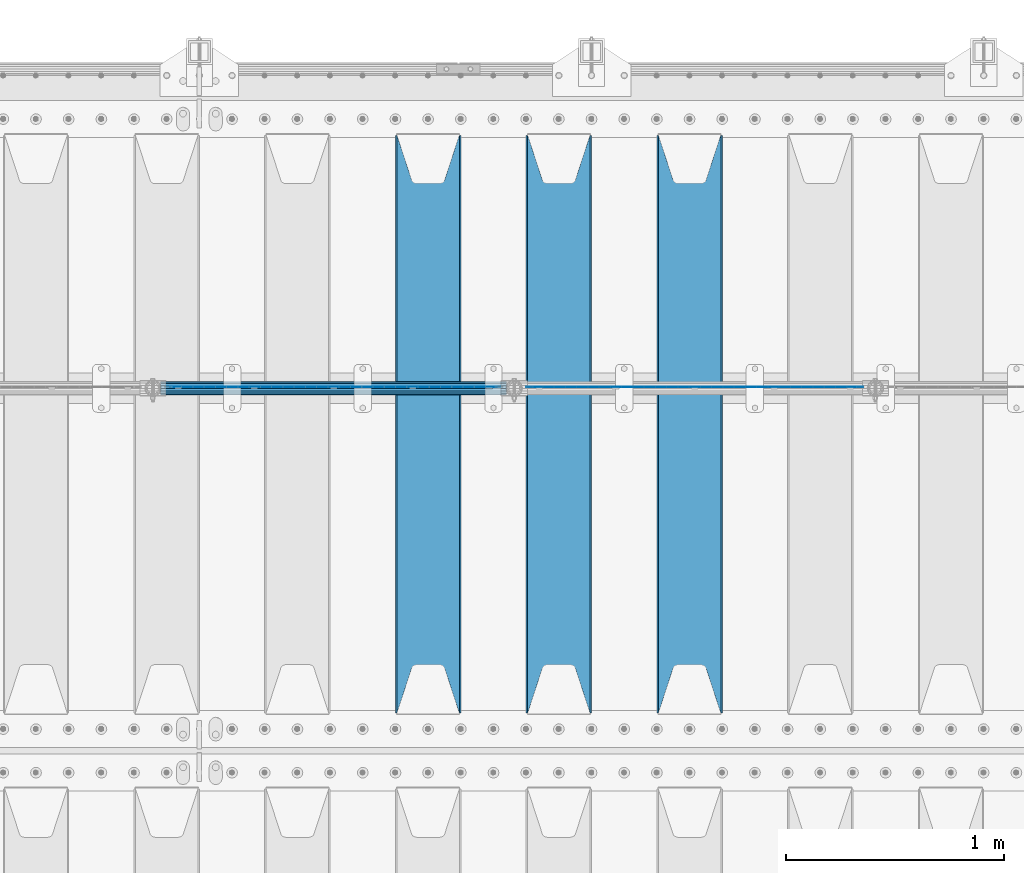
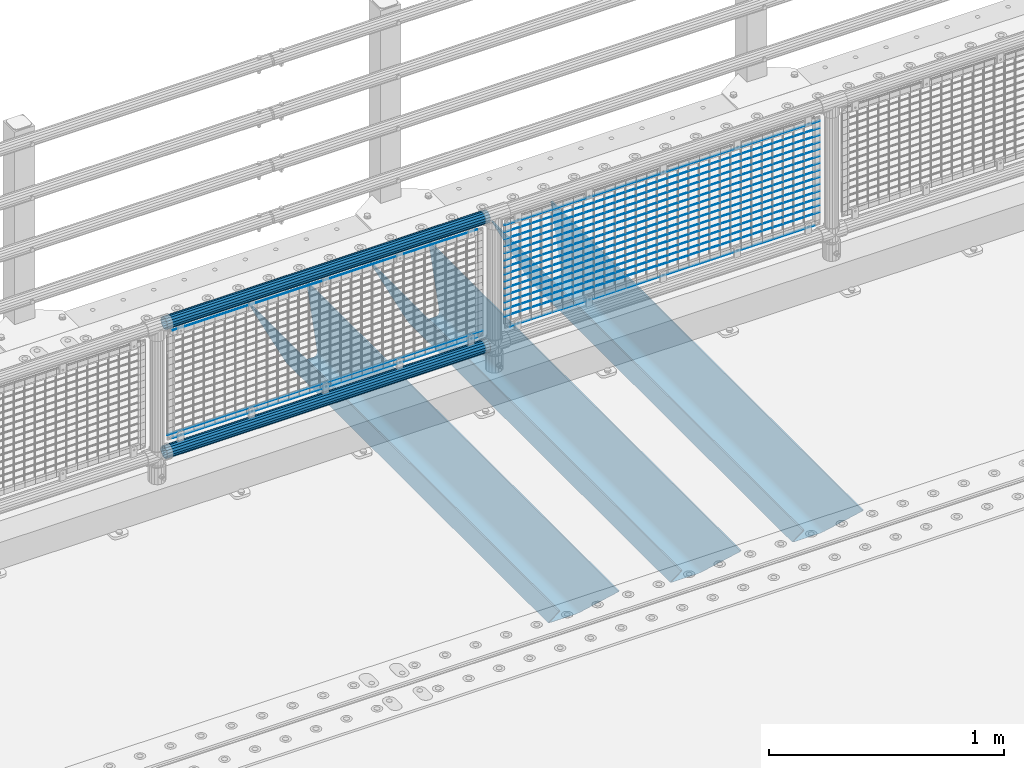
# One storey, part 117 of 240: 23 beams.
"""IFC2X3 building model written with IfcOpenShell, lengths in millimetres."""

import ifcopenshell
import ifcopenshell.guid

model = None  # the IFC model being written
_history = None  # IfcOwnerHistory: only IFC2X3 demands one
_inside = {}  # id of a spatial element -> (the spatial element, [elements in it])
_under = {}  # id of a project, library or spatial element -> (it, [spatial elements below it])
_declared = {}  # id of a project -> (the project, [libraries it declares])
_typed = {}  # id of a type object -> (the type object, [elements of that type])
_made_of = {}  # id of a material, layer set ... -> (it, [elements and type objects made of it])


def new_model(schema):
    """Start an empty IFC model of exactly this schema.

    Asked for "IFC4X3", IfcOpenShell would pick the latest addendum, in which some entities
    have other attributes; the version numbers below select the first issue.
    IFC2X3 requires an IfcOwnerHistory on every rooted entity: one is made here for all.
    """
    global model, _history
    if schema == "IFC4X3":
        model = ifcopenshell.file(schema_version=(4, 3, 0, 0))
    else:
        model = ifcopenshell.file(schema=schema)
    _inside.clear()
    _under.clear()
    _declared.clear()
    _typed.clear()
    _made_of.clear()
    _history = None
    if model.schema == "IFC2X3":
        org = make("IfcOrganization", Name="unknown")
        user = make(
            "IfcPersonAndOrganization",
            ThePerson=make("IfcPerson", FamilyName="unknown"),
            TheOrganization=org,
        )
        app = make(
            "IfcApplication",
            ApplicationDeveloper=org,
            Version="unknown",
            ApplicationFullName="unknown",
            ApplicationIdentifier="unknown",
        )
        _history = make(
            "IfcOwnerHistory",
            OwningUser=user,
            OwningApplication=app,
            ChangeAction="ADDED",
            CreationDate=0,
        )
    return model


def make(cls, **values):
    """One entity of the class cls with the attributes given. An attribute that is None is left unset."""
    return model.create_entity(
        cls, **{name: value for name, value in values.items() if value is not None}
    )


def rooted(cls, **values):
    """An entity with a GlobalId (a new one), such as an element, a storey or a relation."""
    return make(cls, GlobalId=ifcopenshell.guid.new(), OwnerHistory=_history, **values)


def si_unit(unit_type, name, prefix=None):
    """IfcSIUnit, for example si_unit("LENGTHUNIT", "METRE", prefix="MILLI")."""
    return make("IfcSIUnit", UnitType=unit_type, Prefix=prefix, Name=name)


def assignment(units):
    """IfcUnitAssignment: the units of a project."""
    return None if units is None else make("IfcUnitAssignment", Units=units)


def point(xyz):
    """IfcCartesianPoint."""
    return None if xyz is None else make("IfcCartesianPoint", Coordinates=xyz)


def direction(xyz):
    """IfcDirection."""
    return None if xyz is None else make("IfcDirection", DirectionRatios=xyz)


def frame(location, z_axis=None, x_axis=None):
    """IfcAxis2Placement3D, a coordinate frame: its origin and axes. An axis left out is left unset."""
    return make(
        "IfcAxis2Placement3D",
        Location=point(location),
        Axis=direction(z_axis),
        RefDirection=direction(x_axis),
    )


def origin_with_axes():
    """The frame at (0, 0, 0) with the z axis (0, 0, 1) and the x axis (1, 0, 0) written out."""
    return frame((0.0, 0.0, 0.0), z_axis=(0.0, 0.0, 1.0), x_axis=(1.0, 0.0, 0.0))


def place(relative_to, where):
    """IfcLocalPlacement: puts the frame where relative to a parent placement (None: the world)."""
    return make(
        "IfcLocalPlacement", PlacementRelTo=relative_to, RelativePlacement=where
    )


def context(
    kind, dimensions, precision=None, world=None, true_north=None, identifier=None
):
    """IfcGeometricRepresentationContext, for example the 3D "Model" context."""
    return make(
        "IfcGeometricRepresentationContext",
        ContextIdentifier=identifier,
        ContextType=kind,
        CoordinateSpaceDimension=dimensions,
        Precision=precision,
        WorldCoordinateSystem=world,
        TrueNorth=true_north,
    )


def subcontext(parent, identifier, kind, view, scale=None):
    """IfcGeometricRepresentationSubContext, for example "Body" below "Model"."""
    return make(
        "IfcGeometricRepresentationSubContext",
        ContextIdentifier=identifier,
        ContextType=kind,
        ParentContext=parent,
        TargetScale=scale,
        TargetView=view,
    )


def project(units=None, contexts=None):
    """IfcProject with its units and contexts."""
    return rooted(
        "IfcProject",
        Name="project",
        RepresentationContexts=contexts,
        UnitsInContext=assignment(units),
    )


def spatial(cls, under=None, at=None, **own):
    """A site, building, storey or space (cls), placed at a placement, below another one or the project."""
    s = rooted(cls, ObjectPlacement=at, **own)
    if under is not None:
        _under.setdefault(under.id(), (under, []))[1].append(s)
    return s


def faces_of(points, faces, orient=None, outer=None):
    """IfcFace entities. A face is a list of loops; a loop is a list of indices into points, from 0.

    orient and outer hold one flag for each loop. By default every Orientation is true, the
    first loop of a face is its IfcFaceOuterBound and the others are IfcFaceBound.
    """
    made = []
    for i, loops in enumerate(faces):
        bounds = []
        for j, loop in enumerate(loops):
            is_outer = j == 0 if outer is None else outer[i][j]
            bounds.append(
                make(
                    "IfcFaceOuterBound" if is_outer else "IfcFaceBound",
                    Bound=make("IfcPolyLoop", Polygon=[points[k] for k in loop]),
                    Orientation=True if orient is None else orient[i][j],
                )
            )
        made.append(make("IfcFace", Bounds=bounds))
    return made


def faceted_brep(points, faces, orient=None, outer=None, voids=None):
    """IfcFacetedBrep: a solid bounded by flat faces; with voids (closed shells), ...WithVoids."""
    shared = [point(p) for p in points]
    hull = make("IfcClosedShell", CfsFaces=faces_of(shared, faces, orient, outer))
    if voids is None:
        return make("IfcFacetedBrep", Outer=hull)
    return make(
        "IfcFacetedBrepWithVoids",
        Outer=hull,
        Voids=[
            make(cls, CfsFaces=faces_of(shared, fs, o, b)) for cls, fs, o, b in voids
        ],
    )


def shape(context_of_items, identifier, shape_type, items):
    """IfcShapeRepresentation: the items that make up one representation, for example the "Body"."""
    return make(
        "IfcShapeRepresentation",
        ContextOfItems=context_of_items,
        RepresentationIdentifier=identifier,
        RepresentationType=shape_type,
        Items=items,
    )


def material(Name=None, Category=None):
    """IfcMaterial."""
    return make("IfcMaterial", Name=Name, Category=Category)


def made_of(thing, what):
    """Note that an element or type object is made of a material, layer set ...; save() writes the relation."""
    if what is not None:
        _made_of.setdefault(what.id(), (what, []))[1].append(thing)
    return thing


def type_object(cls, material=None, **own):
    """A type object (cls), such as IfcWallType, which elements share."""
    return made_of(rooted(cls, **own), material)


def element(
    cls,
    number,
    at=None,
    inside=None,
    cuts=None,
    type_object=None,
    material=None,
    context=None,
    identifier="Body",
    shape_type=None,
    held_by="IfcProductDefinitionShape",
    body=None,
    shapes=None,
    **own,
):
    """One element of the class cls, such as IfcWall. Its Tag is "e" and its number.

    at: its placement. inside: the storey or other place that contains it. cuts: it is an
    opening in that element (IfcRelVoidsElement). A single representation is given by context,
    identifier, shape_type and body (its items); several are given by shapes. held_by: the class
    of the entity that holds the representations. save() writes the other relations.
    """
    e = rooted(cls, Tag="e%d" % number, ObjectPlacement=at, **own)
    if body is not None:
        shapes = [shape(context, identifier, shape_type, body)]
    if shapes is not None:
        e.Representation = make(held_by, Representations=shapes)
    if inside is not None:
        _inside.setdefault(inside.id(), (inside, []))[1].append(e)
    if cuts is not None:
        rooted(
            "IfcRelVoidsElement", RelatingBuildingElement=cuts, RelatedOpeningElement=e
        )
    if type_object is not None:
        _typed.setdefault(type_object.id(), (type_object, []))[1].append(e)
    return made_of(e, material)


def aggregate(whole, parts):
    """IfcRelAggregates: a whole, such as a stair, and the parts it consists of."""
    return rooted("IfcRelAggregates", RelatingObject=whole, RelatedObjects=parts)


def save(model, path):
    """Write the relations noted so far, then the file.

    IfcRelAggregates (storeys below a building ...), IfcRelContainedInSpatialStructure (elements
    in a storey), IfcRelDefinesByType, IfcRelAssociatesMaterial and IfcRelDeclares: one each for
    every whole, place, type object, material and project.
    """
    for whole, parts in _under.values():
        aggregate(whole, parts)
    for where, things in _inside.values():
        rooted(
            "IfcRelContainedInSpatialStructure",
            RelatedElements=things,
            RelatingStructure=where,
        )
    for kind, things in _typed.values():
        rooted("IfcRelDefinesByType", RelatedObjects=things, RelatingType=kind)
    for what, things in _made_of.values():
        rooted("IfcRelAssociatesMaterial", RelatedObjects=things, RelatingMaterial=what)
    for by, libraries in _declared.values():
        rooted("IfcRelDeclares", RelatingContext=by, RelatedDefinitions=libraries)
    model.write(path)


model = new_model("IFC2X3")

# Units and contexts
model_context = context("Model", 3, precision=1e-05, world=origin_with_axes())
body_context = subcontext(model_context, "Body", "Model", "MODEL_VIEW")
ifc_project = project(units=[si_unit("LENGTHUNIT", "METRE", prefix="MILLI"), si_unit("AREAUNIT", "SQUARE_METRE"), si_unit("VOLUMEUNIT", "CUBIC_METRE"), si_unit("MASSUNIT", "GRAM", prefix="KILO"), si_unit("TIMEUNIT", "SECOND"), si_unit("PLANEANGLEUNIT", "RADIAN"), si_unit("SOLIDANGLEUNIT", "STERADIAN"), si_unit("THERMODYNAMICTEMPERATUREUNIT", "DEGREE_CELSIUS"), si_unit("LUMINOUSINTENSITYUNIT", "LUMEN")], contexts=[model_context])

# Site, building, storey
site_placement = place(None, origin_with_axes())
site = spatial("IfcSite", under=ifc_project, at=site_placement, CompositionType="ELEMENT")
building_placement = place(site_placement, origin_with_axes())
building = spatial("IfcBuilding", under=site, at=building_placement, Name="Standard", CompositionType="ELEMENT")
storey_placement = place(building_placement, origin_with_axes())
storey = spatial("IfcBuildingStorey", under=building, at=storey_placement, Name="Undefined", CompositionType="ELEMENT", Elevation=0.0)

# Beams
ifc_material_1 = material(Name="STEEL/S355N")
beam_type_1 = type_object("IfcBeamType", PredefinedType="NOTDEFINED")
beam_1_placement = place(storey_placement, frame((48850.0, 33175.0, -115.0), z_axis=(0.0, 0.0, 1.0), x_axis=(0.0, 1.0, 0.0)))
element("IfcBeam", 1, at=beam_1_placement, inside=storey, type_object=beam_type_1, material=ifc_material_1, context=body_context, shape_type="Brep", body=[
    faceted_brep([(0.0, 150.0, 115.0), (0.0, 143.690000000002, 115.0), (2650.00000000297, 143.690000000002, 115.0), (2650.00000000297, 150.0, 115.0), (2650.00000000297, 142.059565218406, 110.000000003094), (2650.00000000297, 148.369565218403, 110.000000003094), (2441.90079219209, -80.1103600731149, -98.0992078077845), (2437.7588105432, -77.5672621345584, -102.241189456673), (2434.06523489747, -74.4080125315522, -105.934765102404), (2430.9108609509, -70.7102721255724, -109.089139048974), (2428.37322971128, -66.5649389910031, -111.626770288588), (2426.51472138055, -62.0739139532889, -113.485278619323), (2425.38102192092, -57.3475956567636, -114.618978078955), (2424.99999999987, -52.5021667386536, -115.0), (2424.99999999987, 52.5021667386536, -115.0), (2425.38102192092, 57.3475956567636, -114.618978078955), (2426.51472138055, 62.0739139532889, -113.485278619323), (2428.37322971128, 66.5649389910031, -111.626770288588), (2430.9108609509, 70.7102721255724, -109.089139048974), (2434.06523489747, 74.4080125315522, -105.934765102404), (2437.7588105432, 77.5672621345584, -102.241189456673), (2441.90079219209, 80.1103600731149, -98.0992078077846), (2446.38936140512, 81.9747917625791, -93.6106385947584), (2448.2494850041, 76.2713538057287, -91.7505149957729), (2444.62967112263, 74.76777986261, -95.3703288772456), (2441.28936334127, 72.7168944282894, -98.710636658607), (2438.31067330439, 70.1691124903809, -101.689326695487), (2435.76682334748, 67.1870637758839, -104.233176652398), (2433.72034654134, 63.8440531834931, -106.279653458539), (2432.22154950042, 60.2222587982324, -107.778450499454), (2431.30727574265, 56.4107117849126, -108.692724257221), (2430.99999999987, 52.5031078186876, -109.0), (2430.99999999987, -52.5031078186876, -109.0), (2431.30727574265, -56.4107117849126, -108.692724257221), (2432.22154950042, -60.2222587982324, -107.778450499454), (2433.72034654134, -63.8440531834931, -106.279653458539), (2435.76682334748, -67.1870637758839, -104.233176652398), (2438.31067330439, -70.1691124903809, -101.689326695487), (2441.28936334127, -72.7168944282894, -98.7106366586071), (2444.62967112263, -74.76777986261, -95.3703288772457), (2448.2494850041, -76.2713538057287, -91.7505149957729), (2650.00000000297, -142.059565218406, 110.000000003094), (2650.00000000297, -148.369565218403, 110.000000003094), (2446.38936140512, -81.9747917625791, -93.6106385947584), (2650.00000000297, -143.690000000002, 115.0), (2650.00000000297, -150.0, 115.0), (0.0, -143.690000000002, 115.0), (0.0, -150.0, 115.0), (0.0, -148.369565218258, 110.000000002667), (203.610638597427, -81.9747917625791, -93.6106385947584), (208.09920781045, -80.1103600731149, -98.0992078077845), (212.241189459342, -77.5672621345584, -102.241189456673), (215.93476510507, -74.4080125315522, -105.934765102404), (219.089139051641, -70.7102721255724, -109.089139048974), (221.626770291256, -66.5649389910031, -111.626770288588), (223.485278621989, -62.0739139532889, -113.485278619323), (224.618978081624, -57.3475956567636, -114.618978078955), (225.000000002663, -52.5021667386536, -115.0), (225.000000002663, 52.5021667386536, -115.0), (224.618978081624, 57.3475956567636, -114.618978078955), (223.485278621989, 62.0739139532889, -113.485278619323), (221.626770291256, 66.5649389910031, -111.626770288588), (219.089139051641, 70.7102721255724, -109.089139048974), (215.93476510507, 74.4080125315522, -105.934765102404), (212.241189459342, 77.5672621345584, -102.241189456673), (208.09920781045, 80.1103600731149, -98.0992078077846), (203.610638597427, 81.9747917625791, -93.6106385947584), (0.0, 148.369565218258, 110.000000002667), (0.0, 142.05956521826, 110.000000002667), (201.750514998439, 76.2713538057287, -91.7505149957729), (205.370328879908, 74.76777986261, -95.3703288772456), (208.710636661275, 72.7168944282894, -98.710636658607), (211.689326698153, 70.1691124903809, -101.689326695487), (214.233176655063, 67.1870637758839, -104.233176652398), (216.279653461206, 63.8440531834931, -106.279653458539), (217.778450502123, 60.2222587982324, -107.778450499454), (218.692724259887, 56.4107117849126, -108.692724257221), (219.000000002667, 52.5031078186876, -109.0), (219.000000002667, -52.5031078186876, -109.0), (218.692724259887, -56.4107117849126, -108.692724257221), (217.778450502123, -60.2222587982324, -107.778450499454), (216.279653461206, -63.8440531834931, -106.279653458539), (214.233176655063, -67.1870637758839, -104.233176652398), (211.689326698153, -70.1691124903809, -101.689326695487), (208.710636661275, -72.7168944282894, -98.7106366586071), (205.370328879915, -74.76777986261, -95.3703288772457), (201.750514998439, -76.2713538057287, -91.7505149957729), (0.0, -142.05956521826, 110.000000002667)], [[[0, 1, 2, 3]], [[3, 2, 4, 5]], [[6, 7, 8, 9, 10, 11, 12, 13, 14, 15, 16, 17, 18, 19, 20, 21, 22, 5, 4, 23, 24, 25, 26, 27, 28, 29, 30, 31, 32, 33, 34, 35, 36, 37, 38, 39, 40, 41, 42, 43]], [[44, 45, 42, 41]], [[46, 47, 45, 44]], [[43, 42, 45, 47, 48, 49]], [[6, 43, 49, 50]], [[7, 6, 50, 51]], [[8, 7, 51, 52]], [[9, 8, 52, 53]], [[10, 9, 53, 54]], [[11, 10, 54, 55]], [[12, 11, 55, 56]], [[13, 12, 56, 57]], [[14, 13, 57, 58]], [[15, 14, 58, 59]], [[16, 15, 59, 60]], [[17, 16, 60, 61]], [[18, 17, 61, 62]], [[19, 18, 62, 63]], [[20, 19, 63, 64]], [[21, 20, 64, 65]], [[22, 21, 65, 66]], [[0, 3, 5, 22, 66, 67]], [[1, 0, 67, 68]], [[23, 4, 2, 1, 68, 69]], [[24, 23, 69, 70]], [[25, 24, 70, 71]], [[26, 25, 71, 72]], [[27, 26, 72, 73]], [[28, 27, 73, 74]], [[29, 28, 74, 75]], [[30, 29, 75, 76]], [[31, 30, 76, 77]], [[32, 31, 77, 78]], [[33, 32, 78, 79]], [[34, 33, 79, 80]], [[35, 34, 80, 81]], [[36, 35, 81, 82]], [[37, 36, 82, 83]], [[38, 37, 83, 84]], [[39, 38, 84, 85]], [[40, 39, 85, 86]], [[46, 44, 41, 40, 86, 87]], [[47, 46, 87, 48]], [[86, 85, 84, 83, 82, 81, 80, 79, 78, 77, 76, 75, 74, 73, 72, 71, 70, 69, 68, 67, 66, 65, 64, 63, 62, 61, 60, 59, 58, 57, 56, 55, 54, 53, 52, 51, 50, 49, 48, 87]]]),
])
beam_2_placement = place(storey_placement, frame((48250.0, 33175.0, -115.0), z_axis=(0.0, 0.0, 1.0), x_axis=(0.0, 1.0, 0.0)))
element("IfcBeam", 2, at=beam_2_placement, inside=storey, type_object=beam_type_1, material=ifc_material_1, context=body_context, shape_type="Brep", body=[
    faceted_brep([(0.0, 150.0, 115.0), (0.0, 143.690000000002, 115.0), (2650.00000000297, 143.690000000002, 115.0), (2650.00000000297, 150.0, 115.0), (2650.00000000297, 142.059565218406, 110.000000003094), (2650.00000000297, 148.369565218403, 110.000000003094), (2441.90079219209, -80.1103600731149, -98.0992078077845), (2437.7588105432, -77.5672621345584, -102.241189456673), (2434.06523489747, -74.4080125315522, -105.934765102404), (2430.9108609509, -70.7102721255724, -109.089139048974), (2428.37322971128, -66.5649389910031, -111.626770288588), (2426.51472138055, -62.0739139532889, -113.485278619323), (2425.38102192092, -57.3475956567636, -114.618978078955), (2424.99999999987, -52.5021667386536, -115.0), (2424.99999999987, 52.5021667386536, -115.0), (2425.38102192092, 57.3475956567636, -114.618978078955), (2426.51472138055, 62.0739139532889, -113.485278619323), (2428.37322971128, 66.5649389910031, -111.626770288588), (2430.9108609509, 70.7102721255724, -109.089139048974), (2434.06523489747, 74.4080125315522, -105.934765102404), (2437.7588105432, 77.5672621345584, -102.241189456673), (2441.90079219209, 80.1103600731149, -98.0992078077846), (2446.38936140512, 81.9747917625791, -93.6106385947584), (2448.2494850041, 76.2713538057287, -91.7505149957729), (2444.62967112263, 74.76777986261, -95.3703288772456), (2441.28936334127, 72.7168944282894, -98.710636658607), (2438.31067330439, 70.1691124903809, -101.689326695487), (2435.76682334748, 67.1870637758839, -104.233176652398), (2433.72034654134, 63.8440531834931, -106.279653458539), (2432.22154950042, 60.2222587982324, -107.778450499454), (2431.30727574265, 56.4107117849126, -108.692724257221), (2430.99999999987, 52.5031078186876, -109.0), (2430.99999999987, -52.5031078186876, -109.0), (2431.30727574265, -56.4107117849126, -108.692724257221), (2432.22154950042, -60.2222587982324, -107.778450499454), (2433.72034654134, -63.8440531834931, -106.279653458539), (2435.76682334748, -67.1870637758839, -104.233176652398), (2438.31067330439, -70.1691124903809, -101.689326695487), (2441.28936334127, -72.7168944282894, -98.7106366586071), (2444.62967112263, -74.76777986261, -95.3703288772457), (2448.2494850041, -76.2713538057287, -91.7505149957729), (2650.00000000297, -142.059565218406, 110.000000003094), (2650.00000000297, -148.369565218403, 110.000000003094), (2446.38936140512, -81.9747917625791, -93.6106385947584), (2650.00000000297, -143.690000000002, 115.0), (2650.00000000297, -150.0, 115.0), (0.0, -143.690000000002, 115.0), (0.0, -150.0, 115.0), (0.0, -148.369565218258, 110.000000002667), (203.610638597427, -81.9747917625791, -93.6106385947584), (208.09920781045, -80.1103600731149, -98.0992078077845), (212.241189459342, -77.5672621345584, -102.241189456673), (215.93476510507, -74.4080125315522, -105.934765102404), (219.089139051641, -70.7102721255724, -109.089139048974), (221.626770291256, -66.5649389910031, -111.626770288588), (223.485278621989, -62.0739139532889, -113.485278619323), (224.618978081624, -57.3475956567636, -114.618978078955), (225.000000002663, -52.5021667386536, -115.0), (225.000000002663, 52.5021667386536, -115.0), (224.618978081624, 57.3475956567636, -114.618978078955), (223.485278621989, 62.0739139532889, -113.485278619323), (221.626770291256, 66.5649389910031, -111.626770288588), (219.089139051641, 70.7102721255724, -109.089139048974), (215.93476510507, 74.4080125315522, -105.934765102404), (212.241189459342, 77.5672621345584, -102.241189456673), (208.09920781045, 80.1103600731149, -98.0992078077846), (203.610638597427, 81.9747917625791, -93.6106385947584), (0.0, 148.369565218258, 110.000000002667), (0.0, 142.05956521826, 110.000000002667), (201.750514998439, 76.2713538057287, -91.7505149957729), (205.370328879908, 74.76777986261, -95.3703288772456), (208.710636661275, 72.7168944282894, -98.710636658607), (211.689326698153, 70.1691124903809, -101.689326695487), (214.233176655063, 67.1870637758839, -104.233176652398), (216.279653461206, 63.8440531834931, -106.279653458539), (217.778450502123, 60.2222587982324, -107.778450499454), (218.692724259887, 56.4107117849126, -108.692724257221), (219.000000002667, 52.5031078186876, -109.0), (219.000000002667, -52.5031078186876, -109.0), (218.692724259887, -56.4107117849126, -108.692724257221), (217.778450502123, -60.2222587982324, -107.778450499454), (216.279653461206, -63.8440531834931, -106.279653458539), (214.233176655063, -67.1870637758839, -104.233176652398), (211.689326698153, -70.1691124903809, -101.689326695487), (208.710636661275, -72.7168944282894, -98.7106366586071), (205.370328879915, -74.76777986261, -95.3703288772457), (201.750514998439, -76.2713538057287, -91.7505149957729), (0.0, -142.05956521826, 110.000000002667)], [[[0, 1, 2, 3]], [[3, 2, 4, 5]], [[6, 7, 8, 9, 10, 11, 12, 13, 14, 15, 16, 17, 18, 19, 20, 21, 22, 5, 4, 23, 24, 25, 26, 27, 28, 29, 30, 31, 32, 33, 34, 35, 36, 37, 38, 39, 40, 41, 42, 43]], [[44, 45, 42, 41]], [[46, 47, 45, 44]], [[43, 42, 45, 47, 48, 49]], [[6, 43, 49, 50]], [[7, 6, 50, 51]], [[8, 7, 51, 52]], [[9, 8, 52, 53]], [[10, 9, 53, 54]], [[11, 10, 54, 55]], [[12, 11, 55, 56]], [[13, 12, 56, 57]], [[14, 13, 57, 58]], [[15, 14, 58, 59]], [[16, 15, 59, 60]], [[17, 16, 60, 61]], [[18, 17, 61, 62]], [[19, 18, 62, 63]], [[20, 19, 63, 64]], [[21, 20, 64, 65]], [[22, 21, 65, 66]], [[0, 3, 5, 22, 66, 67]], [[1, 0, 67, 68]], [[23, 4, 2, 1, 68, 69]], [[24, 23, 69, 70]], [[25, 24, 70, 71]], [[26, 25, 71, 72]], [[27, 26, 72, 73]], [[28, 27, 73, 74]], [[29, 28, 74, 75]], [[30, 29, 75, 76]], [[31, 30, 76, 77]], [[32, 31, 77, 78]], [[33, 32, 78, 79]], [[34, 33, 79, 80]], [[35, 34, 80, 81]], [[36, 35, 81, 82]], [[37, 36, 82, 83]], [[38, 37, 83, 84]], [[39, 38, 84, 85]], [[40, 39, 85, 86]], [[46, 44, 41, 40, 86, 87]], [[47, 46, 87, 48]], [[86, 85, 84, 83, 82, 81, 80, 79, 78, 77, 76, 75, 74, 73, 72, 71, 70, 69, 68, 67, 66, 65, 64, 63, 62, 61, 60, 59, 58, 57, 56, 55, 54, 53, 52, 51, 50, 49, 48, 87]]]),
])
beam_3_placement = place(storey_placement, frame((47650.0, 33175.0, -115.0), z_axis=(0.0, 0.0, 1.0), x_axis=(0.0, 1.0, 0.0)))
element("IfcBeam", 3, at=beam_3_placement, inside=storey, type_object=beam_type_1, material=ifc_material_1, context=body_context, shape_type="Brep", body=[
    faceted_brep([(0.0, 150.0, 115.0), (0.0, 143.690000000002, 115.0), (2650.00000000297, 143.690000000002, 115.0), (2650.00000000297, 150.0, 115.0), (2650.00000000297, 142.059565218406, 110.000000003094), (2650.00000000297, 148.369565218403, 110.000000003094), (2441.90079219209, -80.1103600731149, -98.0992078077845), (2437.7588105432, -77.5672621345584, -102.241189456673), (2434.06523489747, -74.4080125315522, -105.934765102404), (2430.9108609509, -70.7102721255724, -109.089139048974), (2428.37322971128, -66.5649389910031, -111.626770288588), (2426.51472138055, -62.0739139532889, -113.485278619323), (2425.38102192092, -57.3475956567636, -114.618978078955), (2424.99999999987, -52.5021667386536, -115.0), (2424.99999999987, 52.5021667386536, -115.0), (2425.38102192092, 57.3475956567636, -114.618978078955), (2426.51472138055, 62.0739139532889, -113.485278619323), (2428.37322971128, 66.5649389910031, -111.626770288588), (2430.9108609509, 70.7102721255724, -109.089139048974), (2434.06523489747, 74.4080125315522, -105.934765102404), (2437.7588105432, 77.5672621345584, -102.241189456673), (2441.90079219209, 80.1103600731149, -98.0992078077846), (2446.38936140512, 81.9747917625791, -93.6106385947584), (2448.2494850041, 76.2713538057287, -91.7505149957729), (2444.62967112263, 74.76777986261, -95.3703288772456), (2441.28936334127, 72.7168944282894, -98.710636658607), (2438.31067330439, 70.1691124903809, -101.689326695487), (2435.76682334748, 67.1870637758839, -104.233176652398), (2433.72034654134, 63.8440531834931, -106.279653458539), (2432.22154950042, 60.2222587982324, -107.778450499454), (2431.30727574265, 56.4107117849126, -108.692724257221), (2430.99999999987, 52.5031078186876, -109.0), (2430.99999999987, -52.5031078186876, -109.0), (2431.30727574265, -56.4107117849126, -108.692724257221), (2432.22154950042, -60.2222587982324, -107.778450499454), (2433.72034654134, -63.8440531834931, -106.279653458539), (2435.76682334748, -67.1870637758839, -104.233176652398), (2438.31067330439, -70.1691124903809, -101.689326695487), (2441.28936334127, -72.7168944282894, -98.7106366586071), (2444.62967112263, -74.76777986261, -95.3703288772457), (2448.2494850041, -76.2713538057287, -91.7505149957729), (2650.00000000297, -142.059565218406, 110.000000003094), (2650.00000000297, -148.369565218403, 110.000000003094), (2446.38936140512, -81.9747917625791, -93.6106385947584), (2650.00000000297, -143.690000000002, 115.0), (2650.00000000297, -150.0, 115.0), (0.0, -143.690000000002, 115.0), (0.0, -150.0, 115.0), (0.0, -148.369565218258, 110.000000002667), (203.610638597427, -81.9747917625791, -93.6106385947584), (208.09920781045, -80.1103600731149, -98.0992078077845), (212.241189459342, -77.5672621345584, -102.241189456673), (215.93476510507, -74.4080125315522, -105.934765102404), (219.089139051641, -70.7102721255724, -109.089139048974), (221.626770291256, -66.5649389910031, -111.626770288588), (223.485278621989, -62.0739139532889, -113.485278619323), (224.618978081624, -57.3475956567636, -114.618978078955), (225.000000002663, -52.5021667386536, -115.0), (225.000000002663, 52.5021667386536, -115.0), (224.618978081624, 57.3475956567636, -114.618978078955), (223.485278621989, 62.0739139532889, -113.485278619323), (221.626770291256, 66.5649389910031, -111.626770288588), (219.089139051641, 70.7102721255724, -109.089139048974), (215.93476510507, 74.4080125315522, -105.934765102404), (212.241189459342, 77.5672621345584, -102.241189456673), (208.09920781045, 80.1103600731149, -98.0992078077846), (203.610638597427, 81.9747917625791, -93.6106385947584), (0.0, 148.369565218258, 110.000000002667), (0.0, 142.05956521826, 110.000000002667), (201.750514998439, 76.2713538057287, -91.7505149957729), (205.370328879908, 74.76777986261, -95.3703288772456), (208.710636661275, 72.7168944282894, -98.710636658607), (211.689326698153, 70.1691124903809, -101.689326695487), (214.233176655063, 67.1870637758839, -104.233176652398), (216.279653461206, 63.8440531834931, -106.279653458539), (217.778450502123, 60.2222587982324, -107.778450499454), (218.692724259887, 56.4107117849126, -108.692724257221), (219.000000002667, 52.5031078186876, -109.0), (219.000000002667, -52.5031078186876, -109.0), (218.692724259887, -56.4107117849126, -108.692724257221), (217.778450502123, -60.2222587982324, -107.778450499454), (216.279653461206, -63.8440531834931, -106.279653458539), (214.233176655063, -67.1870637758839, -104.233176652398), (211.689326698153, -70.1691124903809, -101.689326695487), (208.710636661275, -72.7168944282894, -98.7106366586071), (205.370328879915, -74.76777986261, -95.3703288772457), (201.750514998439, -76.2713538057287, -91.7505149957729), (0.0, -142.05956521826, 110.000000002667)], [[[0, 1, 2, 3]], [[3, 2, 4, 5]], [[6, 7, 8, 9, 10, 11, 12, 13, 14, 15, 16, 17, 18, 19, 20, 21, 22, 5, 4, 23, 24, 25, 26, 27, 28, 29, 30, 31, 32, 33, 34, 35, 36, 37, 38, 39, 40, 41, 42, 43]], [[44, 45, 42, 41]], [[46, 47, 45, 44]], [[43, 42, 45, 47, 48, 49]], [[6, 43, 49, 50]], [[7, 6, 50, 51]], [[8, 7, 51, 52]], [[9, 8, 52, 53]], [[10, 9, 53, 54]], [[11, 10, 54, 55]], [[12, 11, 55, 56]], [[13, 12, 56, 57]], [[14, 13, 57, 58]], [[15, 14, 58, 59]], [[16, 15, 59, 60]], [[17, 16, 60, 61]], [[18, 17, 61, 62]], [[19, 18, 62, 63]], [[20, 19, 63, 64]], [[21, 20, 64, 65]], [[22, 21, 65, 66]], [[0, 3, 5, 22, 66, 67]], [[1, 0, 67, 68]], [[23, 4, 2, 1, 68, 69]], [[24, 23, 69, 70]], [[25, 24, 70, 71]], [[26, 25, 71, 72]], [[27, 26, 72, 73]], [[28, 27, 73, 74]], [[29, 28, 74, 75]], [[30, 29, 75, 76]], [[31, 30, 76, 77]], [[32, 31, 77, 78]], [[33, 32, 78, 79]], [[34, 33, 79, 80]], [[35, 34, 80, 81]], [[36, 35, 81, 82]], [[37, 36, 82, 83]], [[38, 37, 83, 84]], [[39, 38, 84, 85]], [[40, 39, 85, 86]], [[46, 44, 41, 40, 86, 87]], [[47, 46, 87, 48]], [[86, 85, 84, 83, 82, 81, 80, 79, 78, 77, 76, 75, 74, 73, 72, 71, 70, 69, 68, 67, 66, 65, 64, 63, 62, 61, 60, 59, 58, 57, 56, 55, 54, 53, 52, 51, 50, 49, 48, 87]]]),
])
ifc_material_2 = material(Name="Misc_Undefined")
beam_type_2 = type_object("IfcBeamType", Name="D3", PredefinedType="NOTDEFINED")
for number, where, z_axis, x_axis in (
    (4, (48100.0, 34670.5, 851.597), (0.0, 0.0, 1.0), (1.0, 0.0, 0.0)),
    (5, (48100.0, 34670.5, 669.452), (0.0, 0.0, 1.0), (1.0, 0.0, 0.0)),
    (6, (48100.0, 34670.5, 523.736), (0.0, 0.0, 1.0), (1.0, 0.0, 0.0)),
    (7, (48100.0, 34670.5, 487.307), (0.0, 0.0, 1.0), (1.0, 0.0, 0.0)),
    (8, (48100.0, 34670.5, 705.881), (0.0, 0.0, 1.0), (1.0, 0.0, 0.0)),
    (9, (48100.0, 34670.5, 596.594000000001), (0.0, 0.0, 1.0), (1.0, 0.0, 0.0)),
    (10, (48100.0, 34670.5, 450.878), (0.0, 0.0, 1.0), (1.0, 0.0, 0.0)),
    (11, (48100.0, 34670.5, 815.168), (0.0, 0.0, 1.0), (1.0, 0.0, 0.0)),
    (12, (48100.0, 34670.5, 888.026), (0.0, 0.0, 1.0), (1.0, 0.0, 0.0)),
    (13, (48100.0, 34670.5, 778.739), (0.0, 0.0, 1.0), (1.0, 0.0, 0.0)),
    (14, (48100.0, 34670.5, 742.31), (0.0, 0.0, 1.0), (1.0, 0.0, 0.0)),
    (15, (48100.0, 34670.5, 633.023), (0.0, 0.0, 1.0), (1.0, 0.0, 0.0)),
    (16, (48100.0, 34670.5, 560.165), (0.0, 0.0, 1.0), (1.0, 0.0, 0.0)),
    (17, (48100.0, 34670.5, 414.449), (0.0, 0.0, 1.0), (1.0, 0.0, 0.0)),
):
    element("IfcBeam", number, at=place(storey_placement, frame(where, z_axis=z_axis, x_axis=x_axis)), inside=storey, type_object=beam_type_2, material=ifc_material_2, ObjectType="D3", context=body_context, shape_type="Brep", body=[
        faceted_brep([(-7.27595761418343e-12, -1.49999999999272, 0.0), (-7.27595761418343e-12, -0.749999999992724, -1.29903810567669), (1548.0, -0.75, -1.29903810567669), (1548.0, -1.5, 0.0), (0.0, 0.750000000007276, -1.29903810567669), (1548.0, 0.75, -1.29903810567669), (0.0, 1.50000000000728, 0.0), (1548.0, 1.5, 0.0), (0.0, 0.750000000007276, 1.29903810567669), (1548.0, 0.75, 1.29903810567669), (-7.27595761418343e-12, -0.749999999992724, 1.29903810567669), (1548.0, -0.75, 1.29903810567669)], [[[0, 1, 2, 3]], [[1, 4, 5, 2]], [[4, 6, 7, 5]], [[6, 8, 9, 7]], [[8, 10, 11, 9]], [[10, 0, 3, 11]], [[5, 7, 9, 11, 3, 2]], [[10, 8, 6, 4, 1, 0]]]),
    ])
for number, where, z_axis, x_axis in (
    (18, (48125.0, 34670.5, 353.02), (0.0, 0.0, 1.0), (1.0, 0.0, 0.0)),
    (19, (46467.0, 34670.5, 353.02), (0.0, 0.0, 1.0), (1.0, 0.0, 0.0)),
):
    element("IfcBeam", number, at=place(storey_placement, frame(where, z_axis=z_axis, x_axis=x_axis)), inside=storey, type_object=beam_type_2, material=ifc_material_2, ObjectType="D3", context=body_context, shape_type="Brep", body=[
        faceted_brep([(-7.27595761418343e-12, -1.49999999999272, 0.0), (-7.27595761418343e-12, -0.749999999992724, -1.29903810567669), (1498.0, -0.75, -1.29903810567669), (1498.0, -1.5, 0.0), (0.0, 0.750000000007276, -1.29903810567669), (1498.0, 0.75, -1.29903810567663), (0.0, 1.50000000000728, 0.0), (1498.0, 1.5, 0.0), (0.0, 0.750000000007276, 1.29903810567669), (1498.0, 0.75, 1.29903810567669), (-7.27595761418343e-12, -0.749999999992724, 1.29903810567669), (1498.0, -0.75, 1.29903810567669)], [[[0, 1, 2, 3]], [[1, 4, 5, 2]], [[4, 6, 7, 5]], [[6, 8, 9, 7]], [[8, 10, 11, 9]], [[10, 0, 3, 11]], [[5, 7, 9, 11, 3, 2]], [[10, 8, 6, 4, 1, 0]]]),
    ])
beam_4_placement = place(storey_placement, frame((46442.0, 34670.5, 378.02), z_axis=(0.0, 0.0, 1.0), x_axis=(1.0, 0.0, 0.0)))
element("IfcBeam", 20, at=beam_4_placement, inside=storey, type_object=beam_type_2, material=ifc_material_2, ObjectType="D3", context=body_context, shape_type="Brep", body=[
    faceted_brep([(-7.27595761418343e-12, -1.49999999999272, 0.0), (-7.27595761418343e-12, -0.749999999992724, -1.29903810567669), (1548.0, -0.75, -1.29903810567669), (1548.0, -1.5, 0.0), (0.0, 0.750000000007276, -1.29903810567669), (1548.0, 0.75, -1.29903810567669), (0.0, 1.50000000000728, 0.0), (1548.0, 1.5, 0.0), (0.0, 0.750000000007276, 1.29903810567669), (1548.0, 0.75, 1.29903810567669), (-7.27595761418343e-12, -0.749999999992724, 1.29903810567669), (1548.0, -0.75, 1.29903810567669)], [[[0, 1, 2, 3]], [[1, 4, 5, 2]], [[4, 6, 7, 5]], [[6, 8, 9, 7]], [[8, 10, 11, 9]], [[10, 0, 3, 11]], [[5, 7, 9, 11, 3, 2]], [[10, 8, 6, 4, 1, 0]]]),
])
beam_5_placement = place(storey_placement, frame((46467.0, 34670.5, 913.02), z_axis=(0.0, 0.0, 1.0), x_axis=(1.0, 0.0, 0.0)))
element("IfcBeam", 21, at=beam_5_placement, inside=storey, type_object=beam_type_2, material=ifc_material_2, ObjectType="D3", context=body_context, shape_type="Brep", body=[
    faceted_brep([(-7.27595761418343e-12, -1.49999999999272, 0.0), (-7.27595761418343e-12, -0.749999999992724, -1.29903810567669), (1498.0, -0.75, -1.29903810567669), (1498.0, -1.5, 0.0), (0.0, 0.750000000007276, -1.29903810567669), (1498.0, 0.75, -1.29903810567663), (0.0, 1.50000000000728, 0.0), (1498.0, 1.5, 0.0), (0.0, 0.750000000007276, 1.29903810567669), (1498.0, 0.75, 1.29903810567669), (-7.27595761418343e-12, -0.749999999992724, 1.29903810567669), (1498.0, -0.75, 1.29903810567669)], [[[0, 1, 2, 3]], [[1, 4, 5, 2]], [[4, 6, 7, 5]], [[6, 8, 9, 7]], [[8, 10, 11, 9]], [[10, 0, 3, 11]], [[5, 7, 9, 11, 3, 2]], [[10, 8, 6, 4, 1, 0]]]),
])
ifc_material_3 = material()
beam_type_3 = type_object("IfcBeamType", PredefinedType="NOTDEFINED")
beam_6_placement = place(storey_placement, frame((46421.85, 34664.5, 969.85), z_axis=(0.0, 0.0, 1.0), x_axis=(1.0, 0.0, 0.0)))
element("IfcBeam", 22, at=beam_6_placement, inside=storey, type_object=beam_type_3, material=ifc_material_3, context=body_context, shape_type="Brep", body=[
    faceted_brep([(0.0, -25.3499999999985, 0.0), (0.0, -23.4203461491634, 9.70102501045767), (1588.0, -23.4203461491634, 9.70102501045506), (1588.0, -25.3499999999985, 0.0), (0.0, -17.9251569030821, 17.9251569030821), (1588.0, -17.9251569030821, 17.925156903079), (0.0, -9.70102501045767, 23.4203461491634), (1588.0, -9.70102501045767, 23.4203461491611), (0.0, 0.0, 25.3499999999985), (1588.0, 0.0, 25.35), (0.0, 9.70102501045767, 23.4203461491634), (1588.0, 9.70102501045767, 23.4203461491611), (0.0, 17.9251569030821, 17.9251569030821), (1588.0, 17.9251569030821, 17.925156903079), (0.0, 23.4203461491634, 9.70102501045767), (1588.0, 23.4203461491634, 9.70102501045506), (0.0, 25.3499999999985, 0.0), (1588.0, 25.3499999999985, 0.0), (0.0, 23.4203461491634, -9.70102501045767), (1588.0, 23.4203461491634, -9.70102501045506), (0.0, 17.9251569030821, -17.9251569030821), (1588.0, 17.9251569030821, -17.925156903079), (0.0, 9.70102501045767, -23.4203461491634), (1588.0, 9.70102501045767, -23.4203461491611), (0.0, 0.0, -25.3499999999985), (1588.0, 0.0, -25.35), (0.0, -9.70102501045767, -23.4203461491634), (1588.0, -9.70102501045767, -23.4203461491611), (0.0, -17.9251569030821, -17.9251569030821), (1588.0, -17.9251569030821, -17.925156903079), (0.0, -23.4203461491634, -9.70102501045767), (1588.0, -23.4203461491634, -9.70102501045506), (0.0, -30.1500000000015, 0.0), (0.0, -27.8549679052157, -11.5379054858058), (1588.0, -27.8549679052157, -11.5379054858075), (1588.0, -30.1500000000015, 0.0), (0.0, -21.3192694527752, -21.3192694527752), (1588.0, -21.3192694527752, -21.3192694527744), (0.0, -11.5379054858058, -27.8549679052157), (1588.0, -11.5379054858058, -27.8549679052153), (0.0, 0.0, -30.1500000000015), (1588.0, 0.0, -30.15), (0.0, 11.5379054858058, -27.8549679052157), (1588.0, 11.5379054858058, -27.8549679052153), (0.0, 21.3192694527752, -21.3192694527752), (1588.0, 21.3192694527752, -21.3192694527744), (0.0, 27.8549679052157, -11.5379054858058), (1588.0, 27.8549679052157, -11.5379054858074), (0.0, 30.1500000000015, 0.0), (1588.0, 30.1500000000015, 0.0), (0.0, 27.8549679052157, 11.5379054858058), (1588.0, 27.8549679052157, 11.5379054858074), (0.0, 21.3192694527752, 21.3192694527752), (1588.0, 21.3192694527752, 21.3192694527744), (0.0, 11.5379054858058, 27.8549679052157), (1588.0, 11.5379054858058, 27.8549679052153), (0.0, 0.0, 30.1500000000015), (1588.0, 0.0, 30.15), (0.0, -11.5379054858058, 27.8549679052157), (1588.0, -11.5379054858058, 27.8549679052153), (0.0, -21.3192694527752, 21.3192694527752), (1588.0, -21.3192694527752, 21.3192694527744), (0.0, -27.8549679052157, 11.5379054858058), (1588.0, -27.8549679052157, 11.5379054858074)], [[[0, 1, 2, 3]], [[1, 4, 5, 2]], [[4, 6, 7, 5]], [[6, 8, 9, 7]], [[8, 10, 11, 9]], [[10, 12, 13, 11]], [[12, 14, 15, 13]], [[14, 16, 17, 15]], [[16, 18, 19, 17]], [[18, 20, 21, 19]], [[20, 22, 23, 21]], [[22, 24, 25, 23]], [[24, 26, 27, 25]], [[26, 28, 29, 27]], [[28, 30, 31, 29]], [[30, 0, 3, 31]], [[32, 33, 34, 35]], [[33, 36, 37, 34]], [[36, 38, 39, 37]], [[38, 40, 41, 39]], [[40, 42, 43, 41]], [[42, 44, 45, 43]], [[44, 46, 47, 45]], [[46, 48, 49, 47]], [[48, 50, 51, 49]], [[50, 52, 53, 51]], [[52, 54, 55, 53]], [[54, 56, 57, 55]], [[56, 58, 59, 57]], [[58, 60, 61, 59]], [[60, 62, 63, 61]], [[62, 32, 35, 63]], [[37, 39, 41, 43, 45, 47, 49, 51, 53, 55, 57, 59, 61, 63, 35, 34], [5, 7, 9, 11, 13, 15, 17, 19, 21, 23, 25, 27, 29, 31, 3, 2]], [[62, 60, 58, 56, 54, 52, 50, 48, 46, 44, 42, 40, 38, 36, 33, 32], [30, 28, 26, 24, 22, 20, 18, 16, 14, 12, 10, 8, 6, 4, 1, 0]]]),
])
beam_7_placement = place(storey_placement, frame((46421.85, 34664.5, 298.170000000001), z_axis=(0.0, 0.0, 1.0), x_axis=(1.0, 0.0, 0.0)))
element("IfcBeam", 23, at=beam_7_placement, inside=storey, type_object=beam_type_3, material=ifc_material_3, context=body_context, shape_type="Brep", body=[
    faceted_brep([(0.0, -25.3499999999985, 0.0), (0.0, -23.4203461491634, 9.70102501045767), (1588.0, -23.4203461491634, 9.70102501045506), (1588.0, -25.3499999999985, 0.0), (0.0, -17.9251569030821, 17.9251569030821), (1588.0, -17.9251569030821, 17.925156903079), (0.0, -9.70102501045767, 23.4203461491634), (1588.0, -9.70102501045767, 23.4203461491611), (0.0, 0.0, 25.3499999999985), (1588.0, 0.0, 25.35), (0.0, 9.70102501045767, 23.4203461491634), (1588.0, 9.70102501045767, 23.4203461491611), (0.0, 17.9251569030821, 17.9251569030821), (1588.0, 17.9251569030821, 17.925156903079), (0.0, 23.4203461491634, 9.70102501045767), (1588.0, 23.4203461491634, 9.70102501045506), (0.0, 25.3499999999985, 0.0), (1588.0, 25.3499999999985, 0.0), (0.0, 23.4203461491634, -9.70102501045767), (1588.0, 23.4203461491634, -9.70102501045506), (0.0, 17.9251569030821, -17.9251569030821), (1588.0, 17.9251569030821, -17.925156903079), (0.0, 9.70102501045767, -23.4203461491634), (1588.0, 9.70102501045767, -23.4203461491611), (0.0, 0.0, -25.3499999999985), (1588.0, 0.0, -25.35), (0.0, -9.70102501045767, -23.4203461491634), (1588.0, -9.70102501045767, -23.4203461491611), (0.0, -17.9251569030821, -17.9251569030821), (1588.0, -17.9251569030821, -17.925156903079), (0.0, -23.4203461491634, -9.70102501045767), (1588.0, -23.4203461491634, -9.70102501045506), (0.0, -30.1500000000015, 0.0), (0.0, -27.8549679052157, -11.5379054858058), (1588.0, -27.8549679052157, -11.5379054858075), (1588.0, -30.1500000000015, 0.0), (0.0, -21.3192694527752, -21.3192694527752), (1588.0, -21.3192694527752, -21.3192694527744), (0.0, -11.5379054858058, -27.8549679052157), (1588.0, -11.5379054858058, -27.8549679052153), (0.0, 0.0, -30.1500000000015), (1588.0, 0.0, -30.15), (0.0, 11.5379054858058, -27.8549679052157), (1588.0, 11.5379054858058, -27.8549679052153), (0.0, 21.3192694527752, -21.3192694527752), (1588.0, 21.3192694527752, -21.3192694527744), (0.0, 27.8549679052157, -11.5379054858058), (1588.0, 27.8549679052157, -11.5379054858074), (0.0, 30.1500000000015, 0.0), (1588.0, 30.1500000000015, 0.0), (0.0, 27.8549679052157, 11.5379054858058), (1588.0, 27.8549679052157, 11.5379054858074), (0.0, 21.3192694527752, 21.3192694527752), (1588.0, 21.3192694527752, 21.3192694527744), (0.0, 11.5379054858058, 27.8549679052157), (1588.0, 11.5379054858058, 27.8549679052153), (0.0, 0.0, 30.1500000000015), (1588.0, 0.0, 30.15), (0.0, -11.5379054858058, 27.8549679052157), (1588.0, -11.5379054858058, 27.8549679052153), (0.0, -21.3192694527752, 21.3192694527752), (1588.0, -21.3192694527752, 21.3192694527744), (0.0, -27.8549679052157, 11.5379054858058), (1588.0, -27.8549679052157, 11.5379054858074)], [[[0, 1, 2, 3]], [[1, 4, 5, 2]], [[4, 6, 7, 5]], [[6, 8, 9, 7]], [[8, 10, 11, 9]], [[10, 12, 13, 11]], [[12, 14, 15, 13]], [[14, 16, 17, 15]], [[16, 18, 19, 17]], [[18, 20, 21, 19]], [[20, 22, 23, 21]], [[22, 24, 25, 23]], [[24, 26, 27, 25]], [[26, 28, 29, 27]], [[28, 30, 31, 29]], [[30, 0, 3, 31]], [[32, 33, 34, 35]], [[33, 36, 37, 34]], [[36, 38, 39, 37]], [[38, 40, 41, 39]], [[40, 42, 43, 41]], [[42, 44, 45, 43]], [[44, 46, 47, 45]], [[46, 48, 49, 47]], [[48, 50, 51, 49]], [[50, 52, 53, 51]], [[52, 54, 55, 53]], [[54, 56, 57, 55]], [[56, 58, 59, 57]], [[58, 60, 61, 59]], [[60, 62, 63, 61]], [[62, 32, 35, 63]], [[37, 39, 41, 43, 45, 47, 49, 51, 53, 55, 57, 59, 61, 63, 35, 34], [5, 7, 9, 11, 13, 15, 17, 19, 21, 23, 25, 27, 29, 31, 3, 2]], [[62, 60, 58, 56, 54, 52, 50, 48, 46, 44, 42, 40, 38, 36, 33, 32], [30, 28, 26, 24, 22, 20, 18, 16, 14, 12, 10, 8, 6, 4, 1, 0]]]),
])

save(model, "model.ifc")
